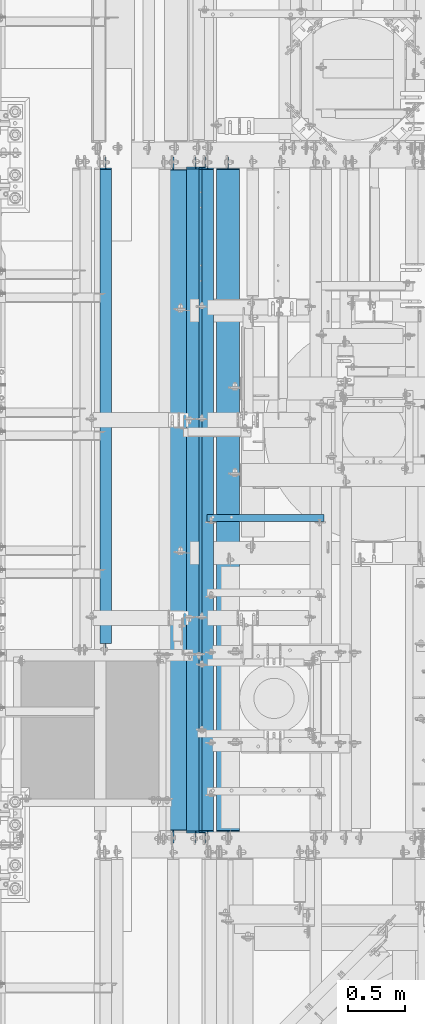
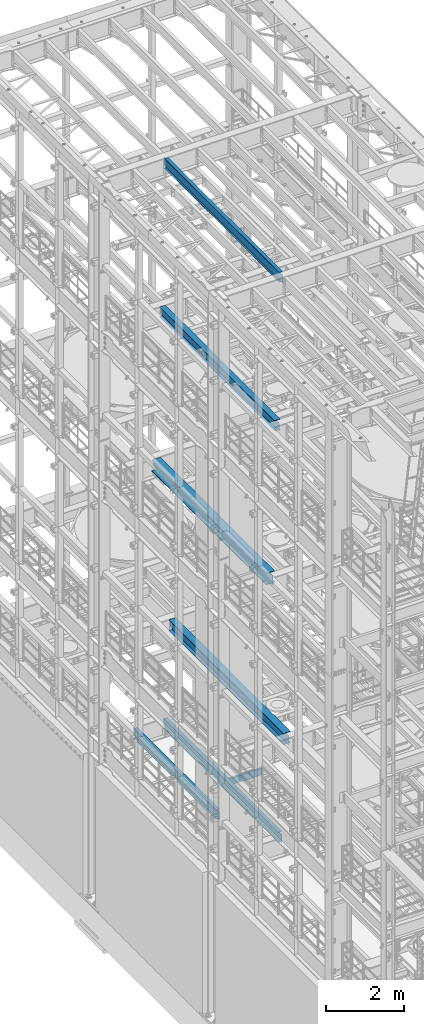
# One storey, part 1024 of 1876: 7 beams, 7 elements without a shape of their own.
"""IFC2X3 building model written with IfcOpenShell, lengths in millimetres."""

from ifc_helpers import new_model, si_unit, frame, origin_with_axes, place, context, subcontext, project, spatial, faceted_brep, material, type_object, element, aggregate, save


model = new_model("IFC2X3")

# Units and contexts
model_context = context("Model", 3, precision=1e-05, world=origin_with_axes())
body_context = subcontext(model_context, "Body", "Model", "MODEL_VIEW")
ifc_project = project(units=[si_unit("LENGTHUNIT", "METRE", prefix="MILLI"), si_unit("AREAUNIT", "SQUARE_METRE"), si_unit("VOLUMEUNIT", "CUBIC_METRE"), si_unit("MASSUNIT", "GRAM", prefix="KILO"), si_unit("TIMEUNIT", "SECOND"), si_unit("PLANEANGLEUNIT", "RADIAN"), si_unit("SOLIDANGLEUNIT", "STERADIAN"), si_unit("THERMODYNAMICTEMPERATUREUNIT", "DEGREE_CELSIUS"), si_unit("LUMINOUSINTENSITYUNIT", "LUMEN")], contexts=[model_context])

# Site, building, storey
site_placement = place(None, origin_with_axes())
site = spatial("IfcSite", under=ifc_project, at=site_placement, CompositionType="ELEMENT")
building_placement = place(site_placement, origin_with_axes())
building = spatial("IfcBuilding", under=site, at=building_placement, Name="Undefined", CompositionType="ELEMENT")
storey_placement = place(building_placement, origin_with_axes())
storey = spatial("IfcBuildingStorey", under=building, at=storey_placement, Name="Undefined", CompositionType="ELEMENT", Elevation=0.0)

# Assembly, beam
assembly_1_placement = place(storey_placement, origin_with_axes())
assembly_1 = element("IfcElementAssembly", 1, at=assembly_1_placement, inside=storey, Name="BEAM", AssemblyPlace="NOTDEFINED", PredefinedType="RIGID_FRAME")
ifc_material_1 = material(Name="STEEL/A992")
beam_type_1 = type_object("IfcBeamType", Name="W12X26", PredefinedType="NOTDEFINED")
beam_1_placement = place(assembly_1_placement, frame((1798.6375, 1524.0, 17827.625), z_axis=(0.0, 0.0, 1.0), x_axis=(0.0, 1.0, 0.0)))
beam_1 = element("IfcBeam", 2, at=beam_1_placement, type_object=beam_type_1, material=ifc_material_1, Name="BEAM", ObjectType="W12X26", context=body_context, shape_type="Brep", body=[
    faceted_brep([(19.8437512414296, -3.17500000000109, -130.175), (19.8437487585795, 3.17499999999927, -130.175), (96.0437824675421, 3.175000000002, -130.175), (96.0437824675423, -3.17499999999745, -130.175), (100.903861985588, 3.175000000002, -131.141729922588), (100.903861985589, -3.17499999999745, -131.141729922588), (105.024038453743, 3.17500000000291, -133.894743823066), (105.024038453744, -3.17499999999654, -133.894743823066), (107.777052354222, 3.17500000000291, -138.01492029122), (107.777052354222, -3.17499999999745, -138.01492029122), (108.743782276811, -3.17499999999654, -142.874999809265), (108.74378227681, 3.17500000000291, -142.874999809265), (108.74375, 3.17500009516311, -146.049999999999), (108.743782276807, 82.5500000000084, -146.05), (108.743782276807, 82.5500000000084, -155.575), (108.743782276814, -82.5500000000029, -155.575), (108.743782276814, -82.5500000000029, -146.05), (108.74375, -3.17499999999995, -146.049999999999), (5969.79375, 82.55, 146.049999999999), (5969.79375, 3.17499999999995, 146.049999999999), (126.20625, 3.17499999999995, 146.049999999999), (126.20625, 82.55, 146.049999999999), (113.506250190735, -3.17499999999995, 111.125000000004), (113.506250190735, 3.17499998562812, 111.125000000004), (19.8437500000002, 3.17499999999995, 111.125000000004), (19.8437500000002, -3.17499999999995, 111.125000000004), (118.36632970878, -3.17499999999995, 112.091729922591), (118.36632970878, 3.17499998547237, 112.091729922591), (122.486506176934, -3.17499999999995, 114.844743823069), (122.486506176934, 3.17499998502694, 114.844743823069), (125.239520077412, -3.17499999999995, 118.964920291222), (125.239520077412, 3.17499998436006, 118.964920291222), (126.20625, -3.17499999999995, 123.824999809269), (126.20625, 3.17499998357312, 123.824999809269), (5969.79375, -82.55, 155.575000000001), (5969.79375, 82.55, 155.575000000001), (126.20625, 82.55, 155.575000000001), (126.20625, -82.55, 155.575000000001), (5969.79375, -82.55, 146.049999999999), (126.20625, -82.55, 146.049999999999), (5969.79375, -3.17499999999995, 146.049999999999), (126.20625, -3.17499999999995, 146.049999999999), (5969.79375, -3.17499999999995, 123.824999809269), (5969.79375, 3.17499999999995, 123.824999809269), (5970.76047992259, -3.17499999999995, 118.964920291222), (5970.76047992259, 3.17499999999995, 118.964920291222), (5973.51349382307, -3.17499999999995, 114.844743823069), (5973.51349382307, 3.17499999999995, 114.844743823069), (5977.63367029122, -3.17499999999995, 112.091729922591), (5977.63367029122, 3.17499999999995, 112.091729922591), (5982.49374980926, -3.17499999999995, 111.125000000004), (5982.49374980926, 3.17499999999995, 111.125000000004), (6076.15625, -3.17499999999995, 111.125000000004), (6076.15625, 3.17499999999995, 111.125000000004), (6076.15625, -3.17499999999995, -130.174999999996), (6076.15625, 3.17499999999995, -130.174999999996), (5999.95624980927, -3.17499999999995, -130.174999999996), (5999.95624980927, 3.17499999999995, -130.174999999996), (5995.09617029122, -3.17499999999995, -131.141729922583), (5995.09617029122, 3.17499999999995, -131.141729922583), (5990.97599382307, -3.17499999999995, -133.894743823061), (5990.97599382307, 3.17499999999995, -133.894743823061), (5988.22297992259, -3.17499999999995, -138.014920291214), (5988.22297992259, 3.17499999999995, -138.014920291214), (5987.25625, -3.17499999999995, -142.874999809261), (5987.25625, 3.17499999999995, -142.874999809261), (5987.25625, -3.17499999999995, -146.049999999999), (5987.25625, -82.55, -146.049999999999), (5987.25625, -82.55, -155.575000000001), (5987.25625, 82.55, -155.575000000001), (5987.25625, 82.55, -146.049999999999), (5987.25625, 3.17499999999995, -146.049999999999)], [[[0, 1, 2, 3]], [[3, 2, 4, 5]], [[5, 4, 6, 7]], [[7, 6, 8, 9]], [[10, 11, 12, 13, 14, 15, 16, 17]], [[9, 8, 11, 10]], [[18, 19, 20, 21]], [[22, 23, 24, 25]], [[26, 27, 23, 22]], [[28, 29, 27, 26]], [[30, 31, 29, 28]], [[32, 33, 31, 30]], [[34, 35, 36, 37]], [[38, 34, 37, 39]], [[40, 38, 39, 41]], [[37, 36, 21, 20, 33, 32, 41, 39]], [[35, 18, 21, 36]], [[34, 38, 40, 42, 43, 19, 18, 35]], [[44, 45, 43, 42]], [[46, 47, 45, 44]], [[48, 49, 47, 46]], [[50, 51, 49, 48]], [[52, 53, 51, 50]], [[53, 52, 54, 55]], [[54, 56, 57, 55]], [[58, 59, 57, 56]], [[60, 61, 59, 58]], [[62, 63, 61, 60]], [[64, 65, 63, 62]], [[66, 67, 68, 69, 70, 71, 65, 64]], [[67, 66, 17, 16]], [[68, 67, 16, 15]], [[69, 68, 15, 14]], [[70, 69, 14, 13]], [[71, 70, 13, 12]], [[6, 4, 2, 1, 24, 23, 27, 29, 31, 33, 20, 19, 43, 45, 47, 49, 51, 53, 55, 57, 59, 61, 63, 65, 71, 12, 11, 8]], [[25, 24, 1, 0]], [[66, 64, 62, 60, 58, 56, 54, 52, 50, 48, 46, 44, 42, 40, 41, 32, 30, 28, 26, 22, 25, 0, 3, 5, 7, 9, 10, 17]]]),
])
aggregate(assembly_1, [beam_1])

assembly_2_placement = place(storey_placement, origin_with_axes())
assembly_2 = element("IfcElementAssembly", 3, at=assembly_2_placement, inside=storey, Name="BEAM", AssemblyPlace="NOTDEFINED", PredefinedType="RIGID_FRAME")
beam_type_2 = type_object("IfcBeamType", Name="W12X16", PredefinedType="NOTDEFINED")
beam_2_placement = place(assembly_2_placement, frame((1905.0, 1524.0, 22402.8), z_axis=(0.0, 0.0, 1.0), x_axis=(0.0, 1.0, 0.0)))
beam_2 = element("IfcBeam", 4, at=beam_2_placement, type_object=beam_type_2, material=ifc_material_1, Name="BEAM", ObjectType="W12X16", context=body_context, shape_type="Brep", body=[
    faceted_brep([(19.84375, -3.17499999999995, -126.999999999996), (19.84375, 3.17499999999995, -126.999999999996), (102.393750190735, 3.17500000000018, -127.000000000001), (102.393750190735, -3.17500000000018, -127.000000000001), (107.25382970878, 3.17500000000018, -127.966729922588), (107.25382970878, -3.17500000000018, -127.966729922588), (111.374006176934, 3.17500000000018, -130.719743823067), (111.374006176934, -3.17500000000018, -130.719743823067), (114.127020077412, 3.17500000000018, -134.839920291221), (114.127020077412, -3.17500000000018, -134.839920291221), (115.09375, -3.17500000000018, -139.699999809266), (115.09375, 3.17500000000018, -139.699999809266), (115.09375, 3.17500000000018, -146.05), (115.09375, 50.8000000000002, -146.05), (115.09375, 50.8000000000002, -152.4), (115.09375, -50.8000000000002, -152.4), (115.09375, -50.8000000000002, -146.05), (115.09375, -3.17500000000018, -146.05), (127.79375, 3.17500000000018, 146.05), (127.79375, 50.8000000000002, 146.05), (5968.20625, 50.8, 146.05), (5968.20625, 3.17499999999995, 146.05), (115.093750190735, -3.17500000000018, 114.299999999999), (115.093750190735, 3.17500000000018, 114.299999999999), (19.84375, 3.17500000000018, 114.299999999999), (19.84375, -3.17500000000018, 114.299999999999), (119.95382970878, -3.17500000000018, 115.266729922587), (119.95382970878, 3.17500000000018, 115.266729922587), (124.074006176934, -3.17500000000018, 118.019743823065), (124.074006176934, 3.17500000000018, 118.019743823065), (126.827020077412, -3.17500000000018, 122.139920291219), (126.827020077412, 3.17500000000018, 122.139920291219), (127.79375, -3.17500000000018, 126.999999809264), (127.79375, 3.17500000000018, 126.999999809264), (127.79375, 50.8000000000002, 152.4), (127.79375, -50.8000000000002, 152.4), (5968.20625, -50.8, 152.4), (5968.20625, 50.8, 152.4), (127.79375, -50.8000000000002, 146.05), (5968.20625, -50.8, 146.05), (127.79375, -3.17500000000018, 146.05), (5968.20625, -3.17499999999995, 146.05), (5968.20625, -3.17499999999995, 126.999999809264), (5968.20625, 3.17499999999995, 126.999999809264), (5969.17297992259, -3.17499999999995, 122.139920291219), (5969.17297992259, 3.17499999999995, 122.139920291219), (5971.92599382307, -3.17499999999995, 118.019743823065), (5971.92599382307, 3.17499999999995, 118.019743823065), (5976.04617029122, -3.17499999999995, 115.266729922587), (5976.04617029122, 3.17499999999995, 115.266729922587), (5980.90624980927, -3.17499999999995, 114.299999999999), (5980.90624980927, 3.17499999999995, 114.299999999999), (6076.15625, -3.17499999999995, 114.299999999999), (6076.15625, 3.17499999999995, 114.299999999999), (6076.15625, -3.17499999999995, -126.999999999996), (6076.15625, 3.17499999999995, -126.999999999996), (5993.60624980927, -3.17499999999995, -127.000000000001), (5993.60624980927, 3.17499999999995, -127.000000000001), (5988.74617029122, -3.17499999999995, -127.966729922588), (5988.74617029122, 3.17499999999995, -127.966729922588), (5984.62599382307, -3.17499999999995, -130.719743823067), (5984.62599382307, 3.17499999999995, -130.719743823067), (5981.87297992259, -3.17499999999995, -134.839920291221), (5981.87297992259, 3.17499999999995, -134.839920291221), (5980.90625, -3.17499999999995, -139.699999809266), (5980.90625, 3.17499999999995, -139.699999809266), (5980.90625, -3.17499999999995, -146.05), (5980.90625, -50.8, -146.05), (5980.90625, -50.8, -152.4), (5980.90625, 50.8, -152.4), (5980.90625, 50.8, -146.05), (5980.90625, 3.17499999999995, -146.05)], [[[0, 1, 2, 3]], [[3, 2, 4, 5]], [[5, 4, 6, 7]], [[7, 6, 8, 9]], [[10, 11, 12, 13, 14, 15, 16, 17]], [[9, 8, 11, 10]], [[18, 19, 20, 21]], [[22, 23, 24, 25]], [[26, 27, 23, 22]], [[28, 29, 27, 26]], [[30, 31, 29, 28]], [[32, 33, 31, 30]], [[34, 35, 36, 37]], [[35, 38, 39, 36]], [[38, 40, 41, 39]], [[35, 34, 19, 18, 33, 32, 40, 38]], [[19, 34, 37, 20]], [[36, 39, 41, 42, 43, 21, 20, 37]], [[44, 45, 43, 42]], [[46, 47, 45, 44]], [[48, 49, 47, 46]], [[50, 51, 49, 48]], [[52, 53, 51, 50]], [[53, 52, 54, 55]], [[54, 56, 57, 55]], [[58, 59, 57, 56]], [[60, 61, 59, 58]], [[62, 63, 61, 60]], [[64, 65, 63, 62]], [[66, 67, 68, 69, 70, 71, 65, 64]], [[17, 16, 67, 66]], [[16, 15, 68, 67]], [[15, 14, 69, 68]], [[14, 13, 70, 69]], [[13, 12, 71, 70]], [[59, 61, 63, 65, 71, 12, 11, 8, 6, 4, 2, 1, 24, 23, 27, 29, 31, 33, 18, 21, 43, 45, 47, 49, 51, 53, 55, 57]], [[25, 24, 1, 0]], [[52, 50, 48, 46, 44, 42, 41, 40, 32, 30, 28, 26, 22, 25, 0, 3, 5, 7, 9, 10, 17, 66, 64, 62, 60, 58, 56, 54]]]),
])
aggregate(assembly_2, [beam_2])

assembly_3_placement = place(storey_placement, origin_with_axes())
assembly_3 = element("IfcElementAssembly", 5, at=assembly_3_placement, inside=storey, Name="BEAM", AssemblyPlace="NOTDEFINED", PredefinedType="RIGID_FRAME")
beam_3_placement = place(assembly_3_placement, frame((1879.6, 1524.0, 4978.4), z_axis=(0.0, 0.0, 1.0), x_axis=(0.0, 1.0, 0.0)))
beam_3 = element("IfcBeam", 6, at=beam_3_placement, type_object=beam_type_2, material=ifc_material_1, Name="BEAM", ObjectType="W12X16", context=body_context, shape_type="Brep", body=[
    faceted_brep([(19.84375, -3.17499999999995, -126.999999999996), (19.84375, 3.17499999999995, -126.999999999996), (102.393750190735, 3.17500000000018, -127.000000000001), (102.393750190735, -3.17500000000018, -127.000000000001), (107.25382970878, 3.17500000000018, -127.966729922588), (107.25382970878, -3.17500000000018, -127.966729922588), (111.374006176934, 3.17500000000018, -130.719743823067), (111.374006176934, -3.17500000000018, -130.719743823067), (114.127020077412, 3.17500000000018, -134.839920291221), (114.127020077412, -3.17500000000018, -134.839920291221), (115.09375, -3.17500000000018, -139.699999809266), (115.09375, 3.17500000000018, -139.699999809266), (115.09375, 3.17500000000018, -146.05), (115.09375, 50.8000000000002, -146.05), (115.09375, 50.8000000000002, -152.4), (115.09375, -50.8000000000002, -152.4), (115.09375, -50.8000000000002, -146.05), (115.09375, -3.17500000000018, -146.05), (127.79375, 3.17500000000018, 146.05), (127.79375, 50.8000000000002, 146.05), (5968.20625, 50.8, 146.05), (5968.20625, 3.17499999999995, 146.05), (115.093750190735, -3.17500000000018, 114.299999999999), (115.093750190735, 3.17500000000018, 114.299999999999), (19.84375, 3.17500000000018, 114.299999999999), (19.84375, -3.17500000000018, 114.299999999999), (119.95382970878, -3.17500000000018, 115.266729922587), (119.95382970878, 3.17500000000018, 115.266729922587), (124.074006176934, -3.17500000000018, 118.019743823065), (124.074006176934, 3.17500000000018, 118.019743823065), (126.827020077412, -3.17500000000018, 122.139920291219), (126.827020077412, 3.17500000000018, 122.139920291219), (127.79375, -3.17500000000018, 126.999999809264), (127.79375, 3.17500000000018, 126.999999809264), (127.79375, 50.8000000000002, 152.4), (127.79375, -50.8000000000002, 152.4), (5968.20625, -50.8, 152.4), (5968.20625, 50.8, 152.4), (127.79375, -50.8000000000002, 146.05), (5968.20625, -50.8, 146.05), (127.79375, -3.17500000000018, 146.05), (5968.20625, -3.17499999999995, 146.05), (5968.20625, -3.17499999999995, 126.999999809264), (5968.20625, 3.17499999999995, 126.999999809264), (5969.17297992259, -3.17499999999995, 122.139920291219), (5969.17297992259, 3.17499999999995, 122.139920291219), (5971.92599382307, -3.17499999999995, 118.019743823065), (5971.92599382307, 3.17499999999995, 118.019743823065), (5976.04617029122, -3.17499999999995, 115.266729922587), (5976.04617029122, 3.17499999999995, 115.266729922587), (5980.90624980927, -3.17499999999995, 114.299999999999), (5980.90624980927, 3.17499999999995, 114.299999999999), (6076.15625, -3.17499999999995, 114.299999999999), (6076.15625, 3.17499999999995, 114.299999999999), (6076.15625, -3.17499999999995, -126.999999999996), (6076.15625, 3.17499999999995, -126.999999999996), (5993.60624980927, -3.17499999999995, -127.000000000001), (5993.60624980927, 3.17499999999995, -127.000000000001), (5988.74617029122, -3.17499999999995, -127.966729922588), (5988.74617029122, 3.17499999999995, -127.966729922588), (5984.62599382307, -3.17499999999995, -130.719743823067), (5984.62599382307, 3.17499999999995, -130.719743823067), (5981.87297992259, -3.17499999999995, -134.839920291221), (5981.87297992259, 3.17499999999995, -134.839920291221), (5980.90625, -3.17499999999995, -139.699999809266), (5980.90625, 3.17499999999995, -139.699999809266), (5980.90625, -3.17499999999995, -146.05), (5980.90625, -50.8, -146.05), (5980.90625, -50.8, -152.4), (5980.90625, 50.8, -152.4), (5980.90625, 50.8, -146.05), (5980.90625, 3.17499999999995, -146.05)], [[[0, 1, 2, 3]], [[3, 2, 4, 5]], [[5, 4, 6, 7]], [[7, 6, 8, 9]], [[10, 11, 12, 13, 14, 15, 16, 17]], [[9, 8, 11, 10]], [[18, 19, 20, 21]], [[22, 23, 24, 25]], [[26, 27, 23, 22]], [[28, 29, 27, 26]], [[30, 31, 29, 28]], [[32, 33, 31, 30]], [[34, 35, 36, 37]], [[35, 38, 39, 36]], [[38, 40, 41, 39]], [[35, 34, 19, 18, 33, 32, 40, 38]], [[19, 34, 37, 20]], [[36, 39, 41, 42, 43, 21, 20, 37]], [[44, 45, 43, 42]], [[46, 47, 45, 44]], [[48, 49, 47, 46]], [[50, 51, 49, 48]], [[52, 53, 51, 50]], [[53, 52, 54, 55]], [[54, 56, 57, 55]], [[58, 59, 57, 56]], [[60, 61, 59, 58]], [[62, 63, 61, 60]], [[64, 65, 63, 62]], [[66, 67, 68, 69, 70, 71, 65, 64]], [[17, 16, 67, 66]], [[16, 15, 68, 67]], [[15, 14, 69, 68]], [[14, 13, 70, 69]], [[13, 12, 71, 70]], [[59, 61, 63, 65, 71, 12, 11, 8, 6, 4, 2, 1, 24, 23, 27, 29, 31, 33, 18, 21, 43, 45, 47, 49, 51, 53, 55, 57]], [[25, 24, 1, 0]], [[52, 50, 48, 46, 44, 42, 41, 40, 32, 30, 28, 26, 22, 25, 0, 3, 5, 7, 9, 10, 17, 66, 64, 62, 60, 58, 56, 54]]]),
])
aggregate(assembly_3, [beam_3])

assembly_4_placement = place(storey_placement, origin_with_axes())
assembly_4 = element("IfcElementAssembly", 7, at=assembly_4_placement, inside=storey, Name="BEAM", AssemblyPlace="NOTDEFINED", PredefinedType="RIGID_FRAME")
beam_4_placement = place(assembly_4_placement, frame((1003.3, 3130.55, 4978.4), z_axis=(0.0, 0.0, 1.0), x_axis=(0.0, 1.0, 0.0)))
beam_4 = element("IfcBeam", 8, at=beam_4_placement, type_object=beam_type_2, material=ifc_material_1, Name="BEAM", ObjectType="W12X16", context=body_context, shape_type="Brep", body=[
    faceted_brep([(85.7250000000013, -3.17499999999995, -127.000000000001), (85.7250000000013, 3.17499999999995, -127.000000000001), (161.925000190735, 3.17499999999995, -127.000000000001), (161.925000190735, -3.17499999999995, -127.000000000001), (166.78507970878, 3.17499999999995, -127.966729922588), (166.78507970878, -3.17499999999995, -127.966729922588), (170.905256176934, 3.17499999999995, -130.719743823067), (170.905256176934, -3.17499999999995, -130.719743823067), (173.658270077412, 3.17499999999995, -134.839920291221), (173.658270077412, -3.17499999999995, -134.839920291221), (174.625, -3.17499999999995, -139.699999809266), (174.625, 3.17499999999995, -139.699999809266), (174.625, 3.17499999999995, -146.05), (174.625, 50.8, -146.05), (174.625, 50.8, -152.4), (174.625, -50.8, -152.4), (174.625, -50.8, -146.05), (174.625, -3.17499999999995, -146.05), (4361.65625, 50.8, 146.05), (4361.65625, 3.17499999999995, 146.05), (174.625, 3.17499999999995, 146.05), (174.625, 50.8, 146.05), (161.925000190735, -3.17499999999995, 126.999999999999), (161.925000190735, 3.17499999999995, 126.999999999999), (85.7250001907378, 3.17500000000018, 127.000000000001), (85.7250001907378, -3.17500000000018, 127.000000000001), (166.78507970878, -3.17499999999995, 127.966729922587), (166.78507970878, 3.17499999999995, 127.966729922587), (170.905256176934, -3.17499999999995, 130.719743823065), (170.905256176934, 3.17499999999995, 130.719743823065), (173.658270077412, -3.17499999999995, 134.839920291219), (173.658270077412, 3.17499999999995, 134.839920291219), (174.625, -3.17499999999995, 139.699999809264), (174.625, 3.17499999999995, 139.699999809264), (4361.65625, -50.8, 152.4), (4361.65625, 50.8, 152.4), (174.625, 50.8, 152.4), (174.625, -50.8, 152.4), (4361.65625, -50.8, 146.05), (174.625, -50.8, 146.05), (4361.65625, -3.17499999999995, 146.05), (174.625, -3.17499999999995, 146.05), (4361.65625, -3.17499999999995, 126.999999809264), (4361.65625, 3.17499999999995, 126.999999809264), (4362.62297992259, -3.17499999999995, 122.139920291219), (4362.62297992259, 3.17499999999995, 122.139920291219), (4365.37599382307, -3.17499999999995, 118.019743823065), (4365.37599382307, 3.17499999999995, 118.019743823065), (4369.49617029122, -3.17499999999995, 115.266729922587), (4369.49617029122, 3.17499999999995, 115.266729922587), (4374.35625, -3.17499999999995, 114.299999999999), (4374.35625, 3.17499999999995, 114.299999999999), (4469.60625, -3.17499999999995, 114.299999999999), (4469.60625, 3.17499999999995, 114.299999999999), (4469.60625, -3.17499999999995, -127.000000000001), (4469.60625, 3.17499999999995, -127.000000000001), (4387.05624980926, -3.17499999999995, -127.000000000001), (4387.05624980926, 3.17499999999995, -127.000000000001), (4382.19617029122, -3.17499999999995, -127.966729922588), (4382.19617029122, 3.17499999999995, -127.966729922588), (4378.07599382307, -3.17499999999995, -130.719743823067), (4378.07599382307, 3.17499999999995, -130.719743823067), (4375.32297992259, -3.17499999999995, -134.839920291221), (4375.32297992259, 3.17499999999995, -134.839920291221), (4374.35625, -3.17499999999995, -139.699999809266), (4374.35625, 3.17499999999995, -139.699999809266), (4374.35625, -3.17499999999995, -146.05), (4374.35625, -50.8, -146.05), (4374.35625, -50.8, -152.4), (4374.35625, 50.8, -152.4), (4374.35625, 50.8, -146.05), (4374.35625, 3.17499999999995, -146.05)], [[[0, 1, 2, 3]], [[3, 2, 4, 5]], [[5, 4, 6, 7]], [[7, 6, 8, 9]], [[10, 11, 12, 13, 14, 15, 16, 17]], [[9, 8, 11, 10]], [[18, 19, 20, 21]], [[22, 23, 24, 25]], [[26, 27, 23, 22]], [[28, 29, 27, 26]], [[30, 31, 29, 28]], [[32, 33, 31, 30]], [[34, 35, 36, 37]], [[38, 34, 37, 39]], [[40, 38, 39, 41]], [[37, 36, 21, 20, 33, 32, 41, 39]], [[35, 18, 21, 36]], [[34, 38, 40, 42, 43, 19, 18, 35]], [[44, 45, 43, 42]], [[46, 47, 45, 44]], [[48, 49, 47, 46]], [[50, 51, 49, 48]], [[52, 53, 51, 50]], [[53, 52, 54, 55]], [[54, 56, 57, 55]], [[58, 59, 57, 56]], [[60, 61, 59, 58]], [[62, 63, 61, 60]], [[64, 65, 63, 62]], [[66, 67, 68, 69, 70, 71, 65, 64]], [[67, 66, 17, 16]], [[68, 67, 16, 15]], [[69, 68, 15, 14]], [[70, 69, 14, 13]], [[71, 70, 13, 12]], [[6, 4, 2, 1, 24, 23, 27, 29, 31, 33, 20, 19, 43, 45, 47, 49, 51, 53, 55, 57, 59, 61, 63, 65, 71, 12, 11, 8]], [[25, 24, 1, 0]], [[66, 64, 62, 60, 58, 56, 54, 52, 50, 48, 46, 44, 42, 40, 41, 32, 30, 28, 26, 22, 25, 0, 3, 5, 7, 9, 10, 17]]]),
])
aggregate(assembly_4, [beam_4])

assembly_5_placement = place(storey_placement, origin_with_axes())
assembly_5 = element("IfcElementAssembly", 9, at=assembly_5_placement, inside=storey, Name="BEAM", AssemblyPlace="NOTDEFINED", PredefinedType="RIGID_FRAME")
ifc_material_2 = material(Name="STEEL/A36")
beam_type_3 = type_object("IfcBeamType", Name="C8X18.75", PredefinedType="NOTDEFINED")
beam_5_placement = place(assembly_5_placement, frame((1880.15454293187, 4413.24959106446, 4981.575), z_axis=(0.0, 0.0, -1.0), x_axis=(1.0, 0.0, 0.0)))
beam_5 = element("IfcBeam", 10, at=beam_5_placement, type_object=beam_type_3, material=ifc_material_2, Name="BEAM", ObjectType="C8X18.75", context=body_context, shape_type="Brep", body=[
    faceted_brep([(15.3204570681301, 31.75, -101.6), (15.3204570681301, 31.75, 101.6), (1050.37045706813, 31.75, 101.6), (1050.37045706813, 31.75, -101.6), (15.3204570681301, -31.75, 101.6), (1050.37045706813, -31.75, 101.6), (15.3204570681301, -31.75, 97.3645500000002), (1050.37045706813, -31.75, 97.3645500000002), (15.3204570681301, 19.05, 88.9012700000003), (1050.37045706813, 19.05, 88.9012700000003), (15.3204570681301, 19.05, -88.9012700000003), (1050.37045706813, 19.05, -88.9012700000003), (15.3204570681301, -31.75, -97.3645500000002), (1050.37045706813, -31.75, -97.3645500000002), (15.3204570681301, -31.75, -101.6), (1050.37045706813, -31.75, -101.6)], [[[0, 1, 2, 3]], [[1, 4, 5, 2]], [[4, 6, 7, 5]], [[6, 8, 9, 7]], [[8, 10, 11, 9]], [[10, 12, 13, 11]], [[12, 14, 15, 13]], [[14, 0, 3, 15]], [[5, 7, 9, 11, 13, 15, 3, 2]], [[14, 12, 10, 8, 6, 4, 1, 0]]]),
])
aggregate(assembly_5, [beam_5])

assembly_6_placement = place(storey_placement, origin_with_axes())
assembly_6 = element("IfcElementAssembly", 11, at=assembly_6_placement, inside=storey, Name="BEAM", AssemblyPlace="NOTDEFINED", PredefinedType="RIGID_FRAME")
beam_type_4 = type_object("IfcBeamType", Name="W14X48", PredefinedType="NOTDEFINED")
beam_6_placement = place(assembly_6_placement, frame((2082.8, 1524.0, 7978.775), z_axis=(0.0, 0.0, 1.0), x_axis=(0.0, 1.0, 0.0)))
beam_6 = element("IfcBeam", 12, at=beam_6_placement, type_object=beam_type_4, material=ifc_material_1, Name="BEAM", ObjectType="W14X48", context=body_context, shape_type="Brep", body=[
    faceted_brep([(19.8437500000002, -3.96875, -149.225000000001), (19.8437500000002, 3.96875, -149.225000000001), (108.743750190735, 3.96875, -149.225000000001), (108.743750190735, -3.96875, -149.225000000001), (113.60382970878, 3.96875, -150.191729922589), (113.60382970878, -3.96875, -150.191729922589), (117.724006176934, 3.96875, -152.944743823067), (117.724006176934, -3.96875, -152.944743823067), (120.477020077412, 3.96875, -157.064920291221), (120.477020077412, -3.96875, -157.064920291221), (121.44375, -101.6, -161.924999809266), (121.44375, 101.6, -161.924999809266), (121.443749999999, 101.6, -174.625), (121.443749999999, -101.6, -174.625), (120.812203271508, -101.6, -158.75), (120.812203271508, -3.96875, -158.75), (120.812203271508, 3.96875, -158.75), (120.812203271508, 101.6, -158.75), (5968.20625, 101.6, 158.75), (5968.20625, 3.96875, 158.75), (127.79375, 3.96875, 158.75), (127.79375, 101.6, 158.75), (115.093750190735, -3.96875, 136.524999999999), (115.093750190735, 3.96875, 136.524999999999), (19.8437500000002, 3.96875, 136.524999999999), (19.8437500000002, -3.96875, 136.524999999999), (119.95382970878, -3.96875, 137.491729922586), (119.95382970878, 3.96875, 137.491729922586), (124.074006176934, -3.96875, 140.244743823065), (124.074006176934, 3.96875, 140.244743823065), (126.827020077412, -3.96875, 144.364920291218), (126.827020077412, 3.96875, 144.364920291218), (127.79375, -3.96875, 149.224999809264), (127.79375, 3.96875, 149.224999809264), (5968.20625, -101.6, 174.625), (5968.20625, 101.6, 174.625), (127.79375, 101.6, 174.625), (127.79375, -101.6, 174.625), (5968.20625, -101.6, 158.75), (127.79375, -101.6, 158.75), (5968.20625, -3.96875, 158.75), (127.79375, -3.96875, 158.75), (5968.20625, -3.96875, 149.224999809264), (5968.20625, 3.96875, 149.224999809264), (5969.17297992259, -3.96875, 144.364920291218), (5969.17297992259, 3.96875, 144.364920291218), (5971.92599382307, -3.96875, 140.244743823065), (5971.92599382307, 3.96875, 140.244743823065), (5976.04617029122, -3.96875, 137.491729922586), (5976.04617029122, 3.96875, 137.491729922586), (5980.90624980927, -3.96875, 136.524999999999), (5980.90624980927, 3.96875, 136.524999999999), (6076.15625, -3.96875, 136.525), (6076.15625, 3.96875, 136.525), (6076.15625, -3.96875, -149.225000000001), (6076.15625, 3.96875, -149.225000000001), (5987.25624980927, -3.96875, -149.225000000001), (5987.25624980927, 3.96875, -149.225000000001), (5982.39617029122, -3.96875, -150.191729922589), (5982.39617029122, 3.96875, -150.191729922589), (5978.27599382307, -3.96875, -152.944743823067), (5978.27599382307, 3.96875, -152.944743823067), (5975.52297992259, -3.96875, -157.064920291221), (5975.52297992259, 3.96875, -157.064920291221), (5975.18779672849, -3.96875, -158.75), (5975.18779672849, -101.6, -158.75), (5974.55625, -101.6, -161.924999809266), (5974.55625, 101.6, -161.924999809266), (5975.18779672849, 101.6, -158.75), (5975.18779672849, 3.96875, -158.75), (5974.55625, -101.6, -174.625), (5974.55625, 101.6, -174.625)], [[[0, 1, 2, 3]], [[3, 2, 4, 5]], [[5, 4, 6, 7]], [[7, 6, 8, 9]], [[10, 11, 12, 13]], [[14, 15, 9, 8, 16, 17, 11, 10]], [[18, 19, 20, 21]], [[22, 23, 24, 25]], [[26, 27, 23, 22]], [[28, 29, 27, 26]], [[30, 31, 29, 28]], [[32, 33, 31, 30]], [[34, 35, 36, 37]], [[38, 34, 37, 39]], [[40, 38, 39, 41]], [[37, 36, 21, 20, 33, 32, 41, 39]], [[35, 18, 21, 36]], [[34, 38, 40, 42, 43, 19, 18, 35]], [[44, 45, 43, 42]], [[46, 47, 45, 44]], [[48, 49, 47, 46]], [[50, 51, 49, 48]], [[52, 53, 51, 50]], [[53, 52, 54, 55]], [[54, 56, 57, 55]], [[58, 59, 57, 56]], [[60, 61, 59, 58]], [[62, 63, 61, 60]], [[64, 65, 66, 67, 68, 69, 63, 62]], [[70, 71, 67, 66]], [[71, 70, 13, 12]], [[68, 67, 71, 12, 11, 17]], [[69, 68, 17, 16]], [[6, 4, 2, 1, 24, 23, 27, 29, 31, 33, 20, 19, 43, 45, 47, 49, 51, 53, 55, 57, 59, 61, 63, 69, 16, 8]], [[25, 24, 1, 0]], [[64, 62, 60, 58, 56, 54, 52, 50, 48, 46, 44, 42, 40, 41, 32, 30, 28, 26, 22, 25, 0, 3, 5, 7, 9, 15]], [[65, 64, 15, 14]], [[70, 66, 65, 14, 10, 13]]]),
])
aggregate(assembly_6, [beam_6])

assembly_7_placement = place(storey_placement, origin_with_axes())
assembly_7 = element("IfcElementAssembly", 13, at=assembly_7_placement, inside=storey, Name="BEAM", AssemblyPlace="NOTDEFINED", PredefinedType="RIGID_FRAME")
beam_type_5 = type_object("IfcBeamType", Name="W14X68", PredefinedType="NOTDEFINED")
beam_7_placement = place(assembly_7_placement, frame((1600.2, 1524.0, 13131.8), z_axis=(0.0, 0.0, 1.0), x_axis=(0.0, 1.0, 0.0)))
beam_7 = element("IfcBeam", 14, at=beam_7_placement, type_object=beam_type_5, material=ifc_material_1, Name="BEAM", ObjectType="W14X68", context=body_context, shape_type="Brep", body=[
    faceted_brep([(5968.20625, -5.55624999999964, -158.75), (5968.20625, -127.0, -158.75), (5968.20625, -127.0, -177.799999999999), (5968.20625, 127.0, -177.799999999999), (5968.20625, 127.0, -158.75), (5968.20625, 5.55624999999964, -158.75), (5968.20625, 5.55624999999964, -152.399999809264), (5968.20625, -5.55624999999964, -152.399999809264), (5969.17297992259, 5.55624999999964, -147.539920291218), (5969.17297992259, -5.55624999999964, -147.539920291218), (5971.92599382307, 5.55624999999964, -143.419743823064), (5971.92599382307, -5.55624999999964, -143.419743823064), (5976.04617029122, 5.55624999999964, -140.666729922586), (5976.04617029122, -5.55624999999964, -140.666729922586), (5980.90624980927, 5.55624999999964, -139.699999999999), (5980.90624980927, -5.55624999999964, -139.699999999999), (6076.15625, -5.55624999999964, -139.699999999999), (6076.15625, 5.55624999999964, -139.699999999999), (5961.85625, 127.0, 158.75), (5961.85625, 5.55624999999964, 158.75), (134.143749999999, 5.55624999999964, 158.75), (134.143749999999, 127.0, 158.75), (127.79375, -5.55625000000009, -152.399999809264), (127.79375, 5.55625000000009, -152.399999809264), (127.79375, 5.55625000000009, -158.75), (127.79375, 127.0, -158.75), (127.79375, 127.0, -177.799999999999), (127.79375, -127.0, -177.799999999999), (127.79375, -127.0, -158.75), (127.79375, -5.55625000000009, -158.75), (126.827020077412, -5.55625000000009, -147.539920291218), (126.827020077412, 5.55625000000009, -147.539920291218), (124.074006176934, -5.55625000000009, -143.419743823064), (124.074006176934, 5.55625000000009, -143.419743823064), (119.95382970878, -5.55625000000009, -140.666729922586), (119.95382970878, 5.55625000000009, -140.666729922586), (115.093750190735, -5.55625000000009, -139.699999999999), (115.093750190735, 5.55625000000009, -139.699999999999), (19.8437500000002, -5.55625000000009, -139.699999999999), (19.8437500000002, 5.55625000000009, -139.699999999999), (19.8437500000002, -5.55624999999964, 133.35), (19.8437500000002, 5.55624999999964, 133.35), (121.443750190735, -5.55624999999964, 133.35), (121.443750190735, 5.55624999999964, 133.35), (126.30382970878, -5.55624999999964, 134.316729922588), (126.30382970878, 5.55624999999964, 134.316729922588), (130.424006176934, -5.55624999999964, 137.069743823065), (130.424006176934, 5.55624999999964, 137.069743823065), (133.177020077412, -5.55624999999964, 141.189920291219), (133.177020077412, 5.55624999999964, 141.189920291219), (134.14375, -5.55624999999964, 146.049999809266), (134.14375, 5.55624999999964, 146.049999809266), (134.143749999999, -127.0, 177.799999999999), (134.143749999999, 127.0, 177.799999999999), (134.143749999999, -5.55624999999964, 158.75), (134.143749999999, -127.0, 158.75), (5961.85625, -5.55624999999964, 158.75), (5961.85625, -127.0, 158.75), (5961.85625, -127.0, 177.799999999999), (5961.85625, 127.0, 177.799999999999), (5961.85625, -5.55624999999964, 146.049999809266), (5961.85625, 5.55624999999964, 146.049999809266), (5962.82297992259, -5.55624999999964, 141.189920291219), (5962.82297992259, 5.55624999999964, 141.189920291219), (5965.57599382307, -5.55624999999964, 137.069743823065), (5965.57599382307, 5.55624999999964, 137.069743823065), (5969.69617029122, -5.55624999999964, 134.316729922588), (5969.69617029122, 5.55624999999964, 134.316729922588), (5974.55624980926, -5.55624999999964, 133.35), (5974.55624980926, 5.55624999999964, 133.35), (6076.15625, -5.55624999999964, 133.35), (6076.15625, 5.55624999999964, 133.35)], [[[0, 1, 2, 3, 4, 5, 6, 7]], [[7, 6, 8, 9]], [[9, 8, 10, 11]], [[11, 10, 12, 13]], [[13, 12, 14, 15]], [[16, 15, 14, 17]], [[18, 19, 20, 21]], [[22, 23, 24, 25, 26, 27, 28, 29]], [[30, 31, 23, 22]], [[32, 33, 31, 30]], [[34, 35, 33, 32]], [[36, 37, 35, 34]], [[38, 39, 37, 36]], [[40, 41, 39, 38]], [[42, 43, 41, 40]], [[44, 45, 43, 42]], [[46, 47, 45, 44]], [[48, 49, 47, 46]], [[50, 51, 49, 48]], [[52, 53, 21, 20, 51, 50, 54, 55]], [[56, 57, 55, 54]], [[57, 58, 52, 55]], [[58, 59, 53, 52]], [[59, 18, 21, 53]], [[58, 57, 56, 60, 61, 19, 18, 59]], [[62, 63, 61, 60]], [[64, 65, 63, 62]], [[66, 67, 65, 64]], [[68, 69, 67, 66]], [[70, 71, 69, 68]], [[71, 70, 16, 17]], [[12, 10, 8, 6, 5, 24, 23, 31, 33, 35, 37, 39, 41, 43, 45, 47, 49, 51, 20, 19, 61, 63, 65, 67, 69, 71, 17, 14]], [[25, 24, 5, 4]], [[26, 25, 4, 3]], [[27, 26, 3, 2]], [[28, 27, 2, 1]], [[29, 28, 1, 0]], [[70, 68, 66, 64, 62, 60, 56, 54, 50, 48, 46, 44, 42, 40, 38, 36, 34, 32, 30, 22, 29, 0, 7, 9, 11, 13, 15, 16]]]),
])
aggregate(assembly_7, [beam_7])

save(model, "model.ifc")
